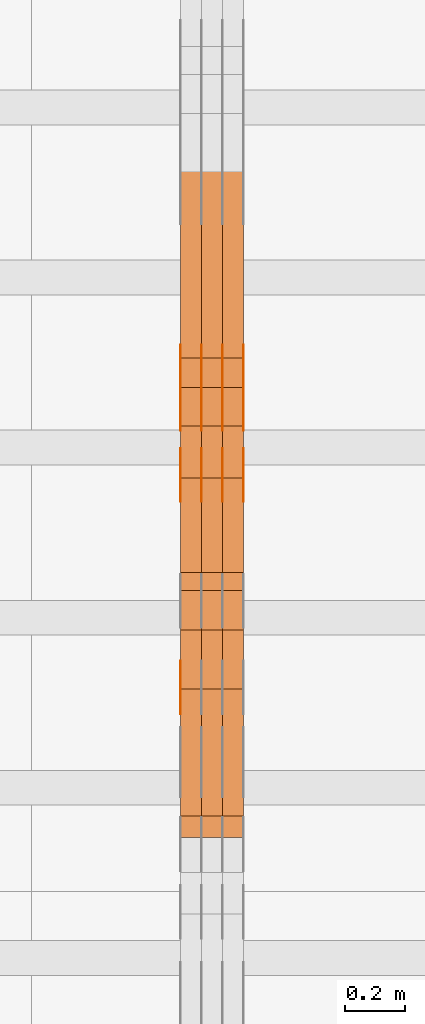
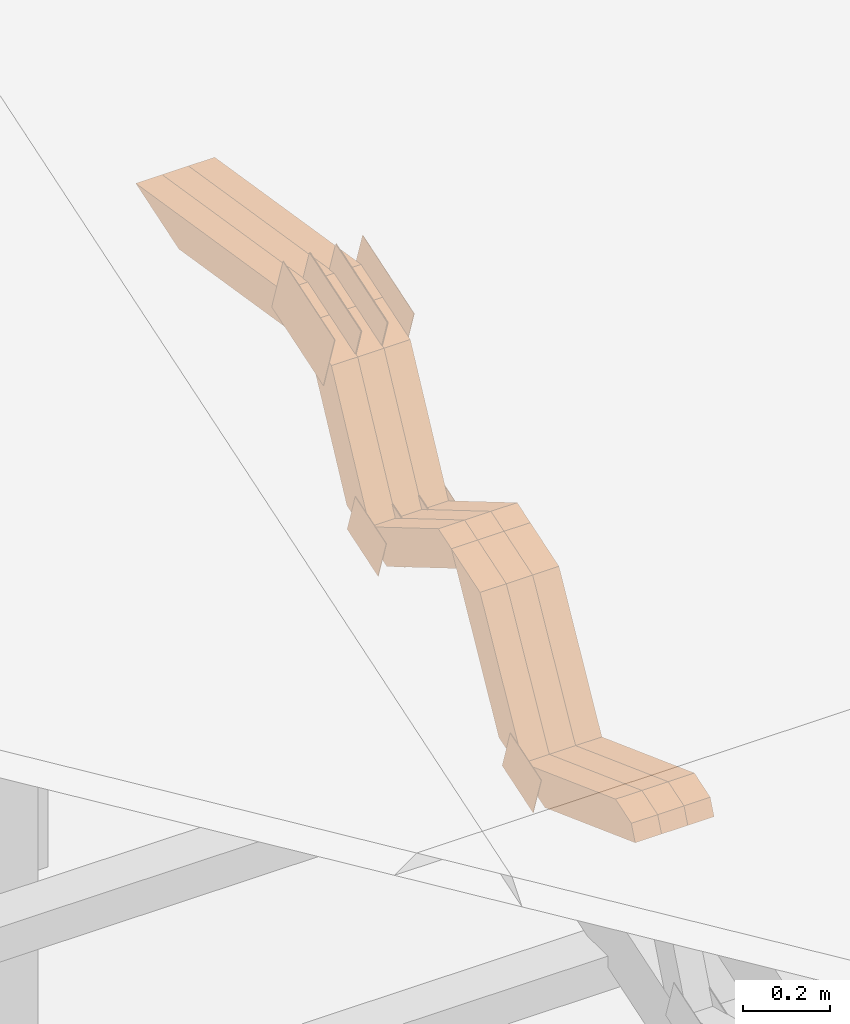
# One storey, part 276 of 385: 28 proxies.
"""IFC2X3 building model written with IfcOpenShell, lengths in millimetres."""

import ifcopenshell
import ifcopenshell.guid

model = None  # the IFC model being written
_history = None  # IfcOwnerHistory: only IFC2X3 demands one
_inside = {}  # id of a spatial element -> (the spatial element, [elements in it])
_under = {}  # id of a project, library or spatial element -> (it, [spatial elements below it])
_declared = {}  # id of a project -> (the project, [libraries it declares])
_typed = {}  # id of a type object -> (the type object, [elements of that type])
_made_of = {}  # id of a material, layer set ... -> (it, [elements and type objects made of it])


def new_model(schema):
    """Start an empty IFC model of exactly this schema.

    Asked for "IFC4X3", IfcOpenShell would pick the latest addendum, in which some entities
    have other attributes; the version numbers below select the first issue.
    IFC2X3 requires an IfcOwnerHistory on every rooted entity: one is made here for all.
    """
    global model, _history
    if schema == "IFC4X3":
        model = ifcopenshell.file(schema_version=(4, 3, 0, 0))
    else:
        model = ifcopenshell.file(schema=schema)
    _inside.clear()
    _under.clear()
    _declared.clear()
    _typed.clear()
    _made_of.clear()
    _history = None
    if model.schema == "IFC2X3":
        org = make("IfcOrganization", Name="unknown")
        user = make(
            "IfcPersonAndOrganization",
            ThePerson=make("IfcPerson", FamilyName="unknown"),
            TheOrganization=org,
        )
        app = make(
            "IfcApplication",
            ApplicationDeveloper=org,
            Version="unknown",
            ApplicationFullName="unknown",
            ApplicationIdentifier="unknown",
        )
        _history = make(
            "IfcOwnerHistory",
            OwningUser=user,
            OwningApplication=app,
            ChangeAction="ADDED",
            CreationDate=0,
        )
    return model


def make(cls, **values):
    """One entity of the class cls with the attributes given. An attribute that is None is left unset."""
    return model.create_entity(
        cls, **{name: value for name, value in values.items() if value is not None}
    )


def entity(cls, *values):
    """Any entity or typed value of the class cls, its attributes in the order of the schema. None: left unset."""
    e = model.create_entity(cls)
    for i, value in enumerate(values):
        if value is not None:
            e[i] = value
    return e


def rooted(cls, **values):
    """An entity with a GlobalId (a new one), such as an element, a storey or a relation."""
    return make(cls, GlobalId=ifcopenshell.guid.new(), OwnerHistory=_history, **values)


def si_unit(unit_type, name, prefix=None):
    """IfcSIUnit, for example si_unit("LENGTHUNIT", "METRE", prefix="MILLI")."""
    return make("IfcSIUnit", UnitType=unit_type, Prefix=prefix, Name=name)


def converted_unit(unit_type, name, factor, base, dimensions=None, offset=None):
    """IfcConversionBasedUnit, such as the inch: factor (a typed value) times the base unit."""
    return make(
        "IfcConversionBasedUnit"
        if offset is None
        else "IfcConversionBasedUnitWithOffset",
        ConversionOffset=offset,
        Dimensions=None
        if dimensions is None
        else entity("IfcDimensionalExponents", *dimensions),
        UnitType=unit_type,
        Name=name,
        ConversionFactor=make(
            "IfcMeasureWithUnit", ValueComponent=factor, UnitComponent=base
        ),
    )


def derived_unit(unit_type, elements):
    """IfcDerivedUnit: a product of units, each with its exponent."""
    return make(
        "IfcDerivedUnit",
        Elements=[
            make("IfcDerivedUnitElement", Unit=unit, Exponent=power)
            for unit, power in elements
        ],
        UnitType=unit_type,
    )


def assignment(units):
    """IfcUnitAssignment: the units of a project."""
    return None if units is None else make("IfcUnitAssignment", Units=units)


def point(xyz):
    """IfcCartesianPoint."""
    return None if xyz is None else make("IfcCartesianPoint", Coordinates=xyz)


def direction(xyz):
    """IfcDirection."""
    return None if xyz is None else make("IfcDirection", DirectionRatios=xyz)


def frame(location, z_axis=None, x_axis=None):
    """IfcAxis2Placement3D, a coordinate frame: its origin and axes. An axis left out is left unset."""
    return make(
        "IfcAxis2Placement3D",
        Location=point(location),
        Axis=direction(z_axis),
        RefDirection=direction(x_axis),
    )


def origin():
    """The frame at (0, 0, 0) with its axes left unset."""
    return frame((0.0, 0.0, 0.0))


def place(relative_to, where):
    """IfcLocalPlacement: puts the frame where relative to a parent placement (None: the world)."""
    return make(
        "IfcLocalPlacement", PlacementRelTo=relative_to, RelativePlacement=where
    )


def context(
    kind, dimensions, precision=None, world=None, true_north=None, identifier=None
):
    """IfcGeometricRepresentationContext, for example the 3D "Model" context."""
    return make(
        "IfcGeometricRepresentationContext",
        ContextIdentifier=identifier,
        ContextType=kind,
        CoordinateSpaceDimension=dimensions,
        Precision=precision,
        WorldCoordinateSystem=world,
        TrueNorth=true_north,
    )


def subcontext(parent, identifier, kind, view, scale=None):
    """IfcGeometricRepresentationSubContext, for example "Body" below "Model"."""
    return make(
        "IfcGeometricRepresentationSubContext",
        ContextIdentifier=identifier,
        ContextType=kind,
        ParentContext=parent,
        TargetScale=scale,
        TargetView=view,
    )


def project(units=None, contexts=None):
    """IfcProject with its units and contexts."""
    return rooted(
        "IfcProject",
        Name="project",
        RepresentationContexts=contexts,
        UnitsInContext=assignment(units),
    )


def spatial(cls, under=None, at=None, **own):
    """A site, building, storey or space (cls), placed at a placement, below another one or the project."""
    s = rooted(cls, ObjectPlacement=at, **own)
    if under is not None:
        _under.setdefault(under.id(), (under, []))[1].append(s)
    return s


def polyline(points):
    """IfcPolyline through the points."""
    return make("IfcPolyline", Points=[point(p) for p in points])


def outline(outer, holes=None, kind="AREA"):
    """IfcArbitraryClosedProfileDef: a profile drawn as a closed curve; with holes, ...WithVoids."""
    if holes is None:
        return make("IfcArbitraryClosedProfileDef", ProfileType=kind, OuterCurve=outer)
    return make(
        "IfcArbitraryProfileDefWithVoids",
        ProfileType=kind,
        OuterCurve=outer,
        InnerCurves=holes,
    )


def extrude(swept, where, along, depth):
    """IfcExtrudedAreaSolid: the profile swept, set in the frame where, extruded along a direction by depth."""
    return make(
        "IfcExtrudedAreaSolid",
        SweptArea=swept,
        Position=where,
        ExtrudedDirection=direction(along),
        Depth=depth,
    )


def shape(context_of_items, identifier, shape_type, items):
    """IfcShapeRepresentation: the items that make up one representation, for example the "Body"."""
    return make(
        "IfcShapeRepresentation",
        ContextOfItems=context_of_items,
        RepresentationIdentifier=identifier,
        RepresentationType=shape_type,
        Items=items,
    )


def source(mapping_origin, context_of_items, identifier, shape_type, items):
    """IfcRepresentationMap: a shape defined once, which mapped items show again and again."""
    return make(
        "IfcRepresentationMap",
        MappingOrigin=mapping_origin,
        MappedRepresentation=shape(context_of_items, identifier, shape_type, items),
    )


def transform(
    local_origin,
    x_axis=None,
    y_axis=None,
    z_axis=None,
    scale=None,
    scale2=None,
    scale3=None,
    uniform=True,
):
    """IfcCartesianTransformationOperator3D, or its non-uniform kind. x_axis, y_axis, z_axis: its Axis1, 2, 3."""
    if uniform:
        return make(
            "IfcCartesianTransformationOperator3D",
            Axis1=direction(x_axis),
            Axis2=direction(y_axis),
            LocalOrigin=point(local_origin),
            Scale=scale,
            Axis3=direction(z_axis),
        )
    return make(
        "IfcCartesianTransformationOperator3DnonUniform",
        Axis1=direction(x_axis),
        Axis2=direction(y_axis),
        LocalOrigin=point(local_origin),
        Scale=scale,
        Axis3=direction(z_axis),
        Scale2=scale2,
        Scale3=scale3,
    )


def mapped(mapping_source, mapping_target):
    """IfcMappedItem: shows the shape of a source again, moved by a transform."""
    return make(
        "IfcMappedItem", MappingSource=mapping_source, MappingTarget=mapping_target
    )


def material(Name=None, Category=None):
    """IfcMaterial."""
    return make("IfcMaterial", Name=Name, Category=Category)


def made_of(thing, what):
    """Note that an element or type object is made of a material, layer set ...; save() writes the relation."""
    if what is not None:
        _made_of.setdefault(what.id(), (what, []))[1].append(thing)
    return thing


def type_object(cls, material=None, **own):
    """A type object (cls), such as IfcWallType, which elements share."""
    return made_of(rooted(cls, **own), material)


def type_shapes(of_type, sources):
    """Give a type object the sources (RepresentationMaps) that its elements show as mapped items."""
    of_type.RepresentationMaps = sources


def element(
    cls,
    number,
    at=None,
    inside=None,
    cuts=None,
    type_object=None,
    material=None,
    context=None,
    identifier="Body",
    shape_type=None,
    held_by="IfcProductDefinitionShape",
    body=None,
    shapes=None,
    **own,
):
    """One element of the class cls, such as IfcWall. Its Tag is "e" and its number.

    at: its placement. inside: the storey or other place that contains it. cuts: it is an
    opening in that element (IfcRelVoidsElement). A single representation is given by context,
    identifier, shape_type and body (its items); several are given by shapes. held_by: the class
    of the entity that holds the representations. save() writes the other relations.
    """
    e = rooted(cls, Tag="e%d" % number, ObjectPlacement=at, **own)
    if body is not None:
        shapes = [shape(context, identifier, shape_type, body)]
    if shapes is not None:
        e.Representation = make(held_by, Representations=shapes)
    if inside is not None:
        _inside.setdefault(inside.id(), (inside, []))[1].append(e)
    if cuts is not None:
        rooted(
            "IfcRelVoidsElement", RelatingBuildingElement=cuts, RelatedOpeningElement=e
        )
    if type_object is not None:
        _typed.setdefault(type_object.id(), (type_object, []))[1].append(e)
    return made_of(e, material)


def aggregate(whole, parts):
    """IfcRelAggregates: a whole, such as a stair, and the parts it consists of."""
    return rooted("IfcRelAggregates", RelatingObject=whole, RelatedObjects=parts)


def save(model, path):
    """Write the relations noted so far, then the file.

    IfcRelAggregates (storeys below a building ...), IfcRelContainedInSpatialStructure (elements
    in a storey), IfcRelDefinesByType, IfcRelAssociatesMaterial and IfcRelDeclares: one each for
    every whole, place, type object, material and project.
    """
    for whole, parts in _under.values():
        aggregate(whole, parts)
    for where, things in _inside.values():
        rooted(
            "IfcRelContainedInSpatialStructure",
            RelatedElements=things,
            RelatingStructure=where,
        )
    for kind, things in _typed.values():
        rooted("IfcRelDefinesByType", RelatedObjects=things, RelatingType=kind)
    for what, things in _made_of.values():
        rooted("IfcRelAssociatesMaterial", RelatedObjects=things, RelatingMaterial=what)
    for by, libraries in _declared.values():
        rooted("IfcRelDeclares", RelatingContext=by, RelatedDefinitions=libraries)
    model.write(path)


model = new_model("IFC2X3")

# Units and contexts
model_context = context("Model", 3, precision=0.01, world=origin(), true_north=direction((6.12303176911189e-17, 1.0)))
body_context = subcontext(model_context, "Body", "Model", "MODEL_VIEW")
ifc_project = project(units=[si_unit("LENGTHUNIT", "METRE", prefix="MILLI"), si_unit("AREAUNIT", "SQUARE_METRE"), si_unit("VOLUMEUNIT", "CUBIC_METRE"), converted_unit("PLANEANGLEUNIT", "DEGREE", entity("IfcRatioMeasure", 0.0174532925199433), si_unit("PLANEANGLEUNIT", "RADIAN"), dimensions=[0, 0, 0, 0, 0, 0, 0]), si_unit("MASSUNIT", "GRAM", prefix="KILO"), derived_unit("MASSDENSITYUNIT", [(si_unit("MASSUNIT", "GRAM", prefix="KILO"), 1), (si_unit("LENGTHUNIT", "METRE"), -3)]), si_unit("TIMEUNIT", "SECOND"), si_unit("FREQUENCYUNIT", "HERTZ"), si_unit("THERMODYNAMICTEMPERATUREUNIT", "DEGREE_CELSIUS"), derived_unit("THERMALTRANSMITTANCEUNIT", [(si_unit("MASSUNIT", "GRAM", prefix="KILO"), 1), (si_unit("THERMODYNAMICTEMPERATUREUNIT", "KELVIN"), -1), (si_unit("TIMEUNIT", "SECOND"), -3)]), derived_unit("VOLUMETRICFLOWRATEUNIT", [(si_unit("LENGTHUNIT", "METRE"), 3), (si_unit("TIMEUNIT", "SECOND"), -1)]), si_unit("ELECTRICCURRENTUNIT", "AMPERE"), si_unit("ELECTRICVOLTAGEUNIT", "VOLT"), si_unit("POWERUNIT", "WATT"), si_unit("FORCEUNIT", "NEWTON", prefix="KILO"), si_unit("ILLUMINANCEUNIT", "LUX"), si_unit("LUMINOUSFLUXUNIT", "LUMEN"), si_unit("LUMINOUSINTENSITYUNIT", "CANDELA"), derived_unit("USERDEFINED", [(si_unit("MASSUNIT", "GRAM", prefix="KILO"), -1), (si_unit("LENGTHUNIT", "METRE"), -2), (si_unit("TIMEUNIT", "SECOND"), 3), (si_unit("LUMINOUSFLUXUNIT", "LUMEN"), 1)]), derived_unit("LINEARVELOCITYUNIT", [(si_unit("LENGTHUNIT", "METRE"), 1), (si_unit("TIMEUNIT", "SECOND"), -1)]), si_unit("PRESSUREUNIT", "PASCAL"), derived_unit("USERDEFINED", [(si_unit("LENGTHUNIT", "METRE"), -2), (si_unit("MASSUNIT", "GRAM", prefix="KILO"), 1), (si_unit("TIMEUNIT", "SECOND"), -2)])], contexts=[model_context])

# Site, building, storey
site_placement = place(None, origin())
site = spatial("IfcSite", under=ifc_project, at=site_placement, CompositionType="ELEMENT")
building_placement = place(site_placement, origin())
building = spatial("IfcBuilding", under=site, at=building_placement, CompositionType="ELEMENT")
storey_placement = place(building_placement, origin())
storey = spatial("IfcBuildingStorey", under=building, at=storey_placement, Name="Default", CompositionType="ELEMENT", Elevation=0.0)

# Proxies
ifc_material_1 = material(Name="IfcSurfaceStyle #554201")
building_element_proxy_type_1 = type_object("IfcBuildingElementProxyType", PredefinedType="NOTDEFINED", material=ifc_material_1)
shared_shape_1 = source(origin(), body_context, "Body", "SweptSolid", [
    extrude(outline(polyline([(-75.0008041947458, -59.9996998629349), (75.0007893252423, -59.9996998629349), (75.0008041947458, 59.9996998629349), (-75.0007893252423, 59.9996998629349), (-75.0008041947458, -59.9996998629349)])), frame((75.0008041947458, 60.0002282421692, 0.0), z_axis=(0.0, 0.0, 1.0), x_axis=(-1.0, 0.0, 0.0)), (0.0, 0.0, 1.0), 1.29999999999999),
])
type_shapes(building_element_proxy_type_1, [shared_shape_1])
proxy_1_placement = place(building_placement, frame((45175.0, 9291.04882812501, 2194.94482421875), z_axis=(-1.0, 0.0, 0.0), x_axis=(0.0, 0.951056516295124, 0.309016994375039)))
element("IfcBuildingElementProxy", 1, at=proxy_1_placement, inside=storey, type_object=building_element_proxy_type_1, material=ifc_material_1, context=body_context, shape_type="MappedRepresentation", body=[
    mapped(shared_shape_1, transform((0.0, 0.0, 0.0), scale=1.0)),
])
ifc_material_2 = material(Name="IfcSurfaceStyle #554144")
building_element_proxy_type_2 = type_object("IfcBuildingElementProxyType", PredefinedType="NOTDEFINED", material=ifc_material_2)
shared_shape_2 = source(origin(), body_context, "Body", "SweptSolid", [
    extrude(outline(polyline([(-124.999432723313, -83.9999457831645), (125.000177551971, -83.9999457831645), (124.999395001513, 83.9999457831646), (-125.000139830171, 83.9999457831645), (-124.999432723313, -83.9999457831645)])), frame((125.000177551971, 84.0001194377192, 0.0), z_axis=(0.0, 0.0, 1.0), x_axis=(-1.0, 0.0, 0.0)), (0.0, 0.0, 1.0), 1.3),
])
type_shapes(building_element_proxy_type_2, [shared_shape_2])
proxy_2_placement = place(building_placement, frame((45386.3, 10242.0968435407, 2855.88278137571), z_axis=(-1.0, 0.0, 0.0), x_axis=(0.0, 0.951056516295154, 0.309016994374948)))
element("IfcBuildingElementProxy", 2, at=proxy_2_placement, inside=storey, type_object=building_element_proxy_type_2, material=ifc_material_2, context=body_context, shape_type="MappedRepresentation", body=[
    mapped(shared_shape_2, transform((0.0, 0.0, 0.0), scale=1.0)),
])
ifc_material_3 = material(Name="IfcSurfaceStyle #554087")
building_element_proxy_type_3 = type_object("IfcBuildingElementProxyType", PredefinedType="NOTDEFINED", material=ifc_material_3)
shared_shape_3 = source(origin(), body_context, "Body", "SweptSolid", [
    extrude(outline(polyline([(-124.999432723313, -83.9999457831645), (125.000177551971, -83.9999457831645), (124.999395001513, 83.9999457831646), (-125.000139830171, 83.9999457831645), (-124.999432723313, -83.9999457831645)])), frame((125.000177551971, 84.0001194377192, 0.0), z_axis=(0.0, 0.0, 1.0), x_axis=(-1.0, 0.0, 0.0)), (0.0, 0.0, 1.0), 1.3),
])
type_shapes(building_element_proxy_type_3, [shared_shape_3])
proxy_3_placement = place(building_placement, frame((45315.0, 10242.0968435407, 2855.88278137571), z_axis=(-1.0, 0.0, 0.0), x_axis=(0.0, 0.951056516295154, 0.309016994374948)))
element("IfcBuildingElementProxy", 3, at=proxy_3_placement, inside=storey, type_object=building_element_proxy_type_3, material=ifc_material_3, context=body_context, shape_type="MappedRepresentation", body=[
    mapped(shared_shape_3, transform((0.0, 0.0, 0.0), scale=1.0)),
])
ifc_material_4 = material(Name="IfcSurfaceStyle #554030")
building_element_proxy_type_4 = type_object("IfcBuildingElementProxyType", PredefinedType="NOTDEFINED", material=ifc_material_4)
shared_shape_4 = source(origin(), body_context, "Body", "SweptSolid", [
    extrude(outline(polyline([(-124.999432723313, -83.9999457831645), (125.000177551971, -83.9999457831645), (124.999395001513, 83.9999457831646), (-125.000139830171, 83.9999457831645), (-124.999432723313, -83.9999457831645)])), frame((125.000177551971, 84.0001194377192, 0.0), z_axis=(0.0, 0.0, 1.0), x_axis=(-1.0, 0.0, 0.0)), (0.0, 0.0, 1.0), 1.3),
])
type_shapes(building_element_proxy_type_4, [shared_shape_4])
proxy_4_placement = place(building_placement, frame((45316.3, 10242.0968435407, 2855.88278137571), z_axis=(-1.0, 0.0, 0.0), x_axis=(0.0, 0.951056516295154, 0.309016994374948)))
element("IfcBuildingElementProxy", 4, at=proxy_4_placement, inside=storey, type_object=building_element_proxy_type_4, material=ifc_material_4, context=body_context, shape_type="MappedRepresentation", body=[
    mapped(shared_shape_4, transform((0.0, 0.0, 0.0), scale=1.0)),
])
ifc_material_5 = material(Name="IfcSurfaceStyle #553973")
building_element_proxy_type_5 = type_object("IfcBuildingElementProxyType", PredefinedType="NOTDEFINED", material=ifc_material_5)
shared_shape_5 = source(origin(), body_context, "Body", "SweptSolid", [
    extrude(outline(polyline([(-124.999432723313, -83.9999457831645), (125.000177551971, -83.9999457831645), (124.999395001513, 83.9999457831646), (-125.000139830171, 83.9999457831645), (-124.999432723313, -83.9999457831645)])), frame((125.000177551971, 84.0001194377192, 0.0), z_axis=(0.0, 0.0, 1.0), x_axis=(-1.0, 0.0, 0.0)), (0.0, 0.0, 1.0), 1.29999999999998),
])
type_shapes(building_element_proxy_type_5, [shared_shape_5])
proxy_5_placement = place(building_placement, frame((45245.0, 10242.0968435407, 2855.88278137571), z_axis=(-1.0, 0.0, 0.0), x_axis=(0.0, 0.951056516295154, 0.309016994374948)))
element("IfcBuildingElementProxy", 5, at=proxy_5_placement, inside=storey, type_object=building_element_proxy_type_5, material=ifc_material_5, context=body_context, shape_type="MappedRepresentation", body=[
    mapped(shared_shape_5, transform((0.0, 0.0, 0.0), scale=1.0)),
])
ifc_material_6 = material(Name="IfcSurfaceStyle #553916")
building_element_proxy_type_6 = type_object("IfcBuildingElementProxyType", PredefinedType="NOTDEFINED", material=ifc_material_6)
shared_shape_6 = source(origin(), body_context, "Body", "SweptSolid", [
    extrude(outline(polyline([(-124.999432723313, -83.9999457831645), (125.000177551971, -83.9999457831645), (124.999395001513, 83.9999457831646), (-125.000139830171, 83.9999457831645), (-124.999432723313, -83.9999457831645)])), frame((125.000177551971, 84.0001194377192, 0.0), z_axis=(0.0, 0.0, 1.0), x_axis=(-1.0, 0.0, 0.0)), (0.0, 0.0, 1.0), 1.29999999999998),
])
type_shapes(building_element_proxy_type_6, [shared_shape_6])
proxy_6_placement = place(building_placement, frame((45246.3, 10242.0968435407, 2855.88278137571), z_axis=(-1.0, 0.0, 0.0), x_axis=(0.0, 0.951056516295154, 0.309016994374948)))
element("IfcBuildingElementProxy", 6, at=proxy_6_placement, inside=storey, type_object=building_element_proxy_type_6, material=ifc_material_6, context=body_context, shape_type="MappedRepresentation", body=[
    mapped(shared_shape_6, transform((0.0, 0.0, 0.0), scale=1.0)),
])
ifc_material_7 = material(Name="IfcSurfaceStyle #553859")
building_element_proxy_type_7 = type_object("IfcBuildingElementProxyType", PredefinedType="NOTDEFINED", material=ifc_material_7)
shared_shape_7 = source(origin(), body_context, "Body", "SweptSolid", [
    extrude(outline(polyline([(-124.999432723313, -83.9999457831645), (125.000177551971, -83.9999457831645), (124.999395001513, 83.9999457831646), (-125.000139830171, 83.9999457831645), (-124.999432723313, -83.9999457831645)])), frame((125.000177551971, 84.0001194377192, 0.0), z_axis=(0.0, 0.0, 1.0), x_axis=(-1.0, 0.0, 0.0)), (0.0, 0.0, 1.0), 1.29999999999998),
])
type_shapes(building_element_proxy_type_7, [shared_shape_7])
proxy_7_placement = place(building_placement, frame((45175.0, 10242.0968435407, 2855.88278137571), z_axis=(-1.0, 0.0, 0.0), x_axis=(0.0, 0.951056516295154, 0.309016994374948)))
element("IfcBuildingElementProxy", 7, at=proxy_7_placement, inside=storey, type_object=building_element_proxy_type_7, material=ifc_material_7, context=body_context, shape_type="MappedRepresentation", body=[
    mapped(shared_shape_7, transform((0.0, 0.0, 0.0), scale=1.0)),
])
ifc_material_8 = material(Name="IfcSurfaceStyle #552434")
building_element_proxy_type_8 = type_object("IfcBuildingElementProxyType", PredefinedType="NOTDEFINED", material=ifc_material_8)
shared_shape_8 = source(origin(), body_context, "Body", "SweptSolid", [
    extrude(outline(polyline([(-74.9998754286189, -60.0000016373433), (74.9998605591118, -60.0000016373433), (74.9998754286189, 60.0000016373433), (-74.9998605591118, 60.0000016373433), (-74.9998754286189, -60.0000016373433)])), frame((74.9999131819004, 60.0000016373433, 0.0), z_axis=(0.0, 0.0, 1.0), x_axis=(-1.0, 0.0, 0.0)), (0.0, 0.0, 1.0), 1.3),
])
type_shapes(building_element_proxy_type_8, [shared_shape_8])
proxy_8_placement = place(building_placement, frame((45386.3, 10004.8612689908, 2426.87628052724), z_axis=(-1.0, 0.0, 0.0), x_axis=(0.0, 0.951056516295124, 0.309016994375039)))
element("IfcBuildingElementProxy", 8, at=proxy_8_placement, inside=storey, type_object=building_element_proxy_type_8, material=ifc_material_8, context=body_context, shape_type="MappedRepresentation", body=[
    mapped(shared_shape_8, transform((0.0, 0.0, 0.0), scale=1.0)),
])
ifc_material_9 = material(Name="IfcSurfaceStyle #552377")
building_element_proxy_type_9 = type_object("IfcBuildingElementProxyType", PredefinedType="NOTDEFINED", material=ifc_material_9)
shared_shape_9 = source(origin(), body_context, "Body", "SweptSolid", [
    extrude(outline(polyline([(-74.9998754286189, -60.0000016373433), (74.9998605591118, -60.0000016373433), (74.9998754286189, 60.0000016373433), (-74.9998605591118, 60.0000016373433), (-74.9998754286189, -60.0000016373433)])), frame((74.9999131819004, 60.0000016373433, 0.0), z_axis=(0.0, 0.0, 1.0), x_axis=(-1.0, 0.0, 0.0)), (0.0, 0.0, 1.0), 1.3),
])
type_shapes(building_element_proxy_type_9, [shared_shape_9])
proxy_9_placement = place(building_placement, frame((45315.0, 10004.8612689908, 2426.87628052724), z_axis=(-1.0, 0.0, 0.0), x_axis=(0.0, 0.951056516295124, 0.309016994375039)))
element("IfcBuildingElementProxy", 9, at=proxy_9_placement, inside=storey, type_object=building_element_proxy_type_9, material=ifc_material_9, context=body_context, shape_type="MappedRepresentation", body=[
    mapped(shared_shape_9, transform((0.0, 0.0, 0.0), scale=1.0)),
])
ifc_material_10 = material(Name="IfcSurfaceStyle #552320")
building_element_proxy_type_10 = type_object("IfcBuildingElementProxyType", PredefinedType="NOTDEFINED", material=ifc_material_10)
shared_shape_10 = source(origin(), body_context, "Body", "SweptSolid", [
    extrude(outline(polyline([(-74.9998754286189, -60.0000016373433), (74.9998605591118, -60.0000016373433), (74.9998754286189, 60.0000016373433), (-74.9998605591118, 60.0000016373433), (-74.9998754286189, -60.0000016373433)])), frame((74.9999131819004, 60.0000016373433, 0.0), z_axis=(0.0, 0.0, 1.0), x_axis=(-1.0, 0.0, 0.0)), (0.0, 0.0, 1.0), 1.3),
])
type_shapes(building_element_proxy_type_10, [shared_shape_10])
proxy_10_placement = place(building_placement, frame((45316.3, 10004.8612689908, 2426.87628052724), z_axis=(-1.0, 0.0, 0.0), x_axis=(0.0, 0.951056516295124, 0.309016994375039)))
element("IfcBuildingElementProxy", 10, at=proxy_10_placement, inside=storey, type_object=building_element_proxy_type_10, material=ifc_material_10, context=body_context, shape_type="MappedRepresentation", body=[
    mapped(shared_shape_10, transform((0.0, 0.0, 0.0), scale=1.0)),
])
ifc_material_11 = material(Name="IfcSurfaceStyle #552263")
building_element_proxy_type_11 = type_object("IfcBuildingElementProxyType", PredefinedType="NOTDEFINED", material=ifc_material_11)
shared_shape_11 = source(origin(), body_context, "Body", "SweptSolid", [
    extrude(outline(polyline([(-74.9998754286189, -60.0000016373433), (74.9998605591118, -60.0000016373433), (74.9998754286189, 60.0000016373433), (-74.9998605591118, 60.0000016373433), (-74.9998754286189, -60.0000016373433)])), frame((74.9999131819004, 60.0000016373433, 0.0), z_axis=(0.0, 0.0, 1.0), x_axis=(-1.0, 0.0, 0.0)), (0.0, 0.0, 1.0), 1.29999999999999),
])
type_shapes(building_element_proxy_type_11, [shared_shape_11])
proxy_11_placement = place(building_placement, frame((45245.0, 10004.8612689908, 2426.87628052724), z_axis=(-1.0, 0.0, 0.0), x_axis=(0.0, 0.951056516295124, 0.309016994375039)))
element("IfcBuildingElementProxy", 11, at=proxy_11_placement, inside=storey, type_object=building_element_proxy_type_11, material=ifc_material_11, context=body_context, shape_type="MappedRepresentation", body=[
    mapped(shared_shape_11, transform((0.0, 0.0, 0.0), scale=1.0)),
])
ifc_material_12 = material(Name="IfcSurfaceStyle #552206")
building_element_proxy_type_12 = type_object("IfcBuildingElementProxyType", PredefinedType="NOTDEFINED", material=ifc_material_12)
shared_shape_12 = source(origin(), body_context, "Body", "SweptSolid", [
    extrude(outline(polyline([(-74.9998754286189, -60.0000016373433), (74.9998605591118, -60.0000016373433), (74.9998754286189, 60.0000016373433), (-74.9998605591118, 60.0000016373433), (-74.9998754286189, -60.0000016373433)])), frame((74.9999131819004, 60.0000016373433, 0.0), z_axis=(0.0, 0.0, 1.0), x_axis=(-1.0, 0.0, 0.0)), (0.0, 0.0, 1.0), 1.29999999999999),
])
type_shapes(building_element_proxy_type_12, [shared_shape_12])
proxy_12_placement = place(building_placement, frame((45246.3, 10004.8612689908, 2426.87628052724), z_axis=(-1.0, 0.0, 0.0), x_axis=(0.0, 0.951056516295124, 0.309016994375039)))
element("IfcBuildingElementProxy", 12, at=proxy_12_placement, inside=storey, type_object=building_element_proxy_type_12, material=ifc_material_12, context=body_context, shape_type="MappedRepresentation", body=[
    mapped(shared_shape_12, transform((0.0, 0.0, 0.0), scale=1.0)),
])
ifc_material_13 = material(Name="IfcSurfaceStyle #552149")
building_element_proxy_type_13 = type_object("IfcBuildingElementProxyType", PredefinedType="NOTDEFINED", material=ifc_material_13)
shared_shape_13 = source(origin(), body_context, "Body", "SweptSolid", [
    extrude(outline(polyline([(-74.9998754286189, -60.0000016373433), (74.9998605591118, -60.0000016373433), (74.9998754286189, 60.0000016373433), (-74.9998605591118, 60.0000016373433), (-74.9998754286189, -60.0000016373433)])), frame((74.9999131819004, 60.0000016373433, 0.0), z_axis=(0.0, 0.0, 1.0), x_axis=(-1.0, 0.0, 0.0)), (0.0, 0.0, 1.0), 1.29999999999999),
])
type_shapes(building_element_proxy_type_13, [shared_shape_13])
proxy_13_placement = place(building_placement, frame((45175.0, 10004.8612689908, 2426.87628052724), z_axis=(-1.0, 0.0, 0.0), x_axis=(0.0, 0.951056516295124, 0.309016994375039)))
element("IfcBuildingElementProxy", 13, at=proxy_13_placement, inside=storey, type_object=building_element_proxy_type_13, material=ifc_material_13, context=body_context, shape_type="MappedRepresentation", body=[
    mapped(shared_shape_13, transform((0.0, 0.0, 0.0), scale=1.0)),
])
ifc_material_14 = material(Name="IfcSurfaceStyle #532112")
building_element_proxy_type_14 = type_object("IfcBuildingElementProxyType", Name="T1-W5 532110", PredefinedType="NOTDEFINED", material=ifc_material_14)
shared_shape_14 = source(origin(), body_context, "Body", "SweptSolid", [
    extrude(outline(polyline([(-301.214270081322, -47.5000783565111), (303.980395954293, -47.5000783565111), (288.664123931657, 0.000197935560590153), (195.704076557203, 47.4999793887309), (-487.134326361831, 47.4999793887309), (-301.214270081322, -47.5000783565111)])), frame((303.980395954293, 47.5001815410909, 0.0), z_axis=(0.0, 0.0, 1.0), x_axis=(-1.0, 0.0, 0.0)), (0.0, 0.0, 1.0), 70.0),
])
type_shapes(building_element_proxy_type_14, [shared_shape_14])
proxy_14_placement = place(building_placement, frame((45385.0, 10379.2051671398, 2863.91176079486), z_axis=(-1.0, 0.0, 0.0), x_axis=(0.0, 0.987508363398486, -0.1575665961365)))
element("IfcBuildingElementProxy", 14, at=proxy_14_placement, inside=storey, type_object=building_element_proxy_type_14, material=ifc_material_14, Name="T1-W5", context=body_context, shape_type="MappedRepresentation", body=[
    mapped(shared_shape_14, transform((0.0, 0.0, 0.0), scale=1.0)),
])
ifc_material_15 = material(Name="IfcSurfaceStyle #532046")
building_element_proxy_type_15 = type_object("IfcBuildingElementProxyType", Name="T1-W5 532044", PredefinedType="NOTDEFINED", material=ifc_material_15)
shared_shape_15 = source(origin(), body_context, "Body", "SweptSolid", [
    extrude(outline(polyline([(-301.214270081322, -47.5000783565111), (303.980395954293, -47.5000783565111), (288.664123931657, 0.000197935560590153), (195.704076557203, 47.4999793887309), (-487.134326361831, 47.4999793887309), (-301.214270081322, -47.5000783565111)])), frame((303.980395954293, 47.5001815410909, 0.0), z_axis=(0.0, 0.0, 1.0), x_axis=(-1.0, 0.0, 0.0)), (0.0, 0.0, 1.0), 70.0),
])
type_shapes(building_element_proxy_type_15, [shared_shape_15])
proxy_15_placement = place(building_placement, frame((45315.0, 10379.2051671398, 2863.91176079486), z_axis=(-1.0, 0.0, 0.0), x_axis=(0.0, 0.987508363398486, -0.1575665961365)))
element("IfcBuildingElementProxy", 15, at=proxy_15_placement, inside=storey, type_object=building_element_proxy_type_15, material=ifc_material_15, Name="T1-W5", context=body_context, shape_type="MappedRepresentation", body=[
    mapped(shared_shape_15, transform((0.0, 0.0, 0.0), scale=1.0)),
])
ifc_material_16 = material(Name="IfcSurfaceStyle #531980")
building_element_proxy_type_16 = type_object("IfcBuildingElementProxyType", Name="T1-W5 531978", PredefinedType="NOTDEFINED", material=ifc_material_16)
shared_shape_16 = source(origin(), body_context, "Body", "SweptSolid", [
    extrude(outline(polyline([(-301.214270081322, -47.5000783565111), (303.980395954293, -47.5000783565111), (288.664123931657, 0.000197935560590153), (195.704076557203, 47.4999793887309), (-487.134326361831, 47.4999793887309), (-301.214270081322, -47.5000783565111)])), frame((303.980395954293, 47.5001815410909, 0.0), z_axis=(0.0, 0.0, 1.0), x_axis=(-1.0, 0.0, 0.0)), (0.0, 0.0, 1.0), 70.0),
])
type_shapes(building_element_proxy_type_16, [shared_shape_16])
proxy_16_placement = place(building_placement, frame((45245.0, 10379.2051671398, 2863.91176079486), z_axis=(-1.0, 0.0, 0.0), x_axis=(0.0, 0.987508363398486, -0.1575665961365)))
element("IfcBuildingElementProxy", 16, at=proxy_16_placement, inside=storey, type_object=building_element_proxy_type_16, material=ifc_material_16, Name="T1-W5", context=body_context, shape_type="MappedRepresentation", body=[
    mapped(shared_shape_16, transform((0.0, 0.0, 0.0), scale=1.0)),
])
ifc_material_17 = material(Name="IfcSurfaceStyle #531716")
building_element_proxy_type_17 = type_object("IfcBuildingElementProxyType", Name="T1-W37 531714", PredefinedType="NOTDEFINED", material=ifc_material_17)
shared_shape_17 = source(origin(), body_context, "Body", "SweptSolid", [
    extrude(outline(polyline([(111.787482004227, -179.289397746839), (245.990585035629, -179.289397746839), (-64.0177573255029, 131.410401861866), (-131.116409377007, 131.410958895698), (-162.643900337347, 95.757434736113), (111.787482004227, -179.289397746839)])), frame((185.635323570343, 47.5011799885346, 0.0), z_axis=(0.0, 0.0, 1.0), x_axis=(0.706316677358935, 0.707896003156279, 0.0)), (0.0, 0.0, 1.0), 70.0),
])
type_shapes(building_element_proxy_type_17, [shared_shape_17])
proxy_17_placement = place(building_placement, frame((45385.0, 10081.8581176196, 2424.08390440728), z_axis=(-1.0, 0.0, 0.0), x_axis=(0.0, 0.452995827831714, 0.891512635898707)))
element("IfcBuildingElementProxy", 17, at=proxy_17_placement, inside=storey, type_object=building_element_proxy_type_17, material=ifc_material_17, Name="T1-W37", context=body_context, shape_type="MappedRepresentation", body=[
    mapped(shared_shape_17, transform((0.0, 0.0, 0.0), scale=1.0)),
])
ifc_material_18 = material(Name="IfcSurfaceStyle #531650")
building_element_proxy_type_18 = type_object("IfcBuildingElementProxyType", Name="T1-W37 531648", PredefinedType="NOTDEFINED", material=ifc_material_18)
shared_shape_18 = source(origin(), body_context, "Body", "SweptSolid", [
    extrude(outline(polyline([(111.787482004227, -179.289397746839), (245.990585035629, -179.289397746839), (-64.0177573255029, 131.410401861866), (-131.116409377007, 131.410958895698), (-162.643900337347, 95.757434736113), (111.787482004227, -179.289397746839)])), frame((185.635323570343, 47.5011799885346, 0.0), z_axis=(0.0, 0.0, 1.0), x_axis=(0.706316677358935, 0.707896003156279, 0.0)), (0.0, 0.0, 1.0), 70.0),
])
type_shapes(building_element_proxy_type_18, [shared_shape_18])
proxy_18_placement = place(building_placement, frame((45315.0, 10081.8581176196, 2424.08390440728), z_axis=(-1.0, 0.0, 0.0), x_axis=(0.0, 0.452995827831714, 0.891512635898707)))
element("IfcBuildingElementProxy", 18, at=proxy_18_placement, inside=storey, type_object=building_element_proxy_type_18, material=ifc_material_18, Name="T1-W37", context=body_context, shape_type="MappedRepresentation", body=[
    mapped(shared_shape_18, transform((0.0, 0.0, 0.0), scale=1.0)),
])
ifc_material_19 = material(Name="IfcSurfaceStyle #531584")
building_element_proxy_type_19 = type_object("IfcBuildingElementProxyType", Name="T1-W37 531582", PredefinedType="NOTDEFINED", material=ifc_material_19)
shared_shape_19 = source(origin(), body_context, "Body", "SweptSolid", [
    extrude(outline(polyline([(111.787482004227, -179.289397746839), (245.990585035629, -179.289397746839), (-64.0177573255029, 131.410401861866), (-131.116409377007, 131.410958895698), (-162.643900337347, 95.757434736113), (111.787482004227, -179.289397746839)])), frame((185.635323570343, 47.5011799885346, 0.0), z_axis=(0.0, 0.0, 1.0), x_axis=(0.706316677358935, 0.707896003156279, 0.0)), (0.0, 0.0, 1.0), 70.0),
])
type_shapes(building_element_proxy_type_19, [shared_shape_19])
proxy_19_placement = place(building_placement, frame((45245.0, 10081.8581176196, 2424.08390440728), z_axis=(-1.0, 0.0, 0.0), x_axis=(0.0, 0.452995827831714, 0.891512635898707)))
element("IfcBuildingElementProxy", 19, at=proxy_19_placement, inside=storey, type_object=building_element_proxy_type_19, material=ifc_material_19, Name="T1-W37", context=body_context, shape_type="MappedRepresentation", body=[
    mapped(shared_shape_19, transform((0.0, 0.0, 0.0), scale=1.0)),
])
ifc_material_20 = material(Name="IfcSurfaceStyle #531320")
building_element_proxy_type_20 = type_object("IfcBuildingElementProxyType", Name="T1-W43 531318", PredefinedType="NOTDEFINED", material=ifc_material_20)
shared_shape_20 = source(origin(), body_context, "Body", "SweptSolid", [
    extrude(outline(polyline([(-198.159905426436, -47.4999961988362), (173.155878681738, -47.4999961988362), (174.585865234707, -0.00038778214839239), (132.582704932703, 47.5001900899104), (-282.164543422712, 47.5001900899104), (-198.159905426436, -47.4999961988362)])), frame((174.585865234707, 47.5001900899104, 0.0), z_axis=(0.0, 0.0, 1.0), x_axis=(-1.0, 0.0, 0.0)), (0.0, 0.0, 1.0), 70.0),
])
type_shapes(building_element_proxy_type_20, [shared_shape_20])
proxy_20_placement = place(building_placement, frame((45385.0, 9730.71877771153, 2634.4881681647), z_axis=(-1.0, 0.0, 0.0), x_axis=(0.0, 0.861495156633645, -0.507765787639115)))
element("IfcBuildingElementProxy", 20, at=proxy_20_placement, inside=storey, type_object=building_element_proxy_type_20, material=ifc_material_20, Name="T1-W43", context=body_context, shape_type="MappedRepresentation", body=[
    mapped(shared_shape_20, transform((0.0, 0.0, 0.0), scale=1.0)),
])
ifc_material_21 = material(Name="IfcSurfaceStyle #531254")
building_element_proxy_type_21 = type_object("IfcBuildingElementProxyType", Name="T1-W43 531252", PredefinedType="NOTDEFINED", material=ifc_material_21)
shared_shape_21 = source(origin(), body_context, "Body", "SweptSolid", [
    extrude(outline(polyline([(-198.159905426436, -47.4999961988362), (173.155878681738, -47.4999961988362), (174.585865234707, -0.00038778214839239), (132.582704932703, 47.5001900899104), (-282.164543422712, 47.5001900899104), (-198.159905426436, -47.4999961988362)])), frame((174.585865234707, 47.5001900899104, 0.0), z_axis=(0.0, 0.0, 1.0), x_axis=(-1.0, 0.0, 0.0)), (0.0, 0.0, 1.0), 70.0),
])
type_shapes(building_element_proxy_type_21, [shared_shape_21])
proxy_21_placement = place(building_placement, frame((45315.0, 9730.71877771153, 2634.4881681647), z_axis=(-1.0, 0.0, 0.0), x_axis=(0.0, 0.861495156633645, -0.507765787639115)))
element("IfcBuildingElementProxy", 21, at=proxy_21_placement, inside=storey, type_object=building_element_proxy_type_21, material=ifc_material_21, Name="T1-W43", context=body_context, shape_type="MappedRepresentation", body=[
    mapped(shared_shape_21, transform((0.0, 0.0, 0.0), scale=1.0)),
])
ifc_material_22 = material(Name="IfcSurfaceStyle #531188")
building_element_proxy_type_22 = type_object("IfcBuildingElementProxyType", Name="T1-W43 531186", PredefinedType="NOTDEFINED", material=ifc_material_22)
shared_shape_22 = source(origin(), body_context, "Body", "SweptSolid", [
    extrude(outline(polyline([(-198.159905426436, -47.4999961988362), (173.155878681738, -47.4999961988362), (174.585865234707, -0.00038778214839239), (132.582704932703, 47.5001900899104), (-282.164543422712, 47.5001900899104), (-198.159905426436, -47.4999961988362)])), frame((174.585865234707, 47.5001900899104, 0.0), z_axis=(0.0, 0.0, 1.0), x_axis=(-1.0, 0.0, 0.0)), (0.0, 0.0, 1.0), 70.0),
])
type_shapes(building_element_proxy_type_22, [shared_shape_22])
proxy_22_placement = place(building_placement, frame((45245.0, 9730.71877771153, 2634.4881681647), z_axis=(-1.0, 0.0, 0.0), x_axis=(0.0, 0.861495156633645, -0.507765787639115)))
element("IfcBuildingElementProxy", 22, at=proxy_22_placement, inside=storey, type_object=building_element_proxy_type_22, material=ifc_material_22, Name="T1-W43", context=body_context, shape_type="MappedRepresentation", body=[
    mapped(shared_shape_22, transform((0.0, 0.0, 0.0), scale=1.0)),
])
ifc_material_23 = material(Name="IfcSurfaceStyle #530924")
building_element_proxy_type_23 = type_object("IfcBuildingElementProxyType", Name="T1-W33 530922", PredefinedType="NOTDEFINED", material=ifc_material_23)
shared_shape_23 = source(origin(), body_context, "Body", "SweptSolid", [
    extrude(outline(polyline([(-314.173070820175, -47.4997758466969), (139.635944117881, -47.4997758466969), (190.204920608233, 0.000348187720347082), (197.369205310989, 47.5001702328475), (-213.036999216928, 47.4990332728259), (-314.173070820175, -47.4997758466969)])), frame((197.369205310989, 47.5001702328475, 0.0), z_axis=(0.0, 0.0, 1.0), x_axis=(-1.0, 0.0, 0.0)), (0.0, 0.0, 1.0), 70.0),
])
type_shapes(building_element_proxy_type_23, [shared_shape_23])
proxy_23_placement = place(building_placement, frame((45385.0, 9376.96875, 2191.01977539063), z_axis=(-1.0, 0.0, 0.0), x_axis=(0.0, 0.481632628948835, 0.876373214293907)))
element("IfcBuildingElementProxy", 23, at=proxy_23_placement, inside=storey, type_object=building_element_proxy_type_23, material=ifc_material_23, Name="T1-W33", context=body_context, shape_type="MappedRepresentation", body=[
    mapped(shared_shape_23, transform((0.0, 0.0, 0.0), scale=1.0)),
])
ifc_material_24 = material(Name="IfcSurfaceStyle #530858")
building_element_proxy_type_24 = type_object("IfcBuildingElementProxyType", Name="T1-W33 530856", PredefinedType="NOTDEFINED", material=ifc_material_24)
shared_shape_24 = source(origin(), body_context, "Body", "SweptSolid", [
    extrude(outline(polyline([(-314.173070820175, -47.4997758466969), (139.635944117881, -47.4997758466969), (190.204920608233, 0.000348187720347082), (197.369205310989, 47.5001702328475), (-213.036999216928, 47.4990332728259), (-314.173070820175, -47.4997758466969)])), frame((197.369205310989, 47.5001702328475, 0.0), z_axis=(0.0, 0.0, 1.0), x_axis=(-1.0, 0.0, 0.0)), (0.0, 0.0, 1.0), 70.0),
])
type_shapes(building_element_proxy_type_24, [shared_shape_24])
proxy_24_placement = place(building_placement, frame((45315.0, 9376.96875, 2191.01977539063), z_axis=(-1.0, 0.0, 0.0), x_axis=(0.0, 0.481632628948835, 0.876373214293907)))
element("IfcBuildingElementProxy", 24, at=proxy_24_placement, inside=storey, type_object=building_element_proxy_type_24, material=ifc_material_24, Name="T1-W33", context=body_context, shape_type="MappedRepresentation", body=[
    mapped(shared_shape_24, transform((0.0, 0.0, 0.0), scale=1.0)),
])
ifc_material_25 = material(Name="IfcSurfaceStyle #530792")
building_element_proxy_type_25 = type_object("IfcBuildingElementProxyType", Name="T1-W33 530790", PredefinedType="NOTDEFINED", material=ifc_material_25)
shared_shape_25 = source(origin(), body_context, "Body", "SweptSolid", [
    extrude(outline(polyline([(-314.173070820175, -47.4997758466969), (139.635944117881, -47.4997758466969), (190.204920608233, 0.000348187720347082), (197.369205310989, 47.5001702328475), (-213.036999216928, 47.4990332728259), (-314.173070820175, -47.4997758466969)])), frame((197.369205310989, 47.5001702328475, 0.0), z_axis=(0.0, 0.0, 1.0), x_axis=(-1.0, 0.0, 0.0)), (0.0, 0.0, 1.0), 70.0),
])
type_shapes(building_element_proxy_type_25, [shared_shape_25])
proxy_25_placement = place(building_placement, frame((45245.0, 9376.96875, 2191.01977539063), z_axis=(-1.0, 0.0, 0.0), x_axis=(0.0, 0.481632628948835, 0.876373214293907)))
element("IfcBuildingElementProxy", 25, at=proxy_25_placement, inside=storey, type_object=building_element_proxy_type_25, material=ifc_material_25, Name="T1-W33", context=body_context, shape_type="MappedRepresentation", body=[
    mapped(shared_shape_25, transform((0.0, 0.0, 0.0), scale=1.0)),
])
ifc_material_26 = material(Name="IfcSurfaceStyle #530528")
building_element_proxy_type_26 = type_object("IfcBuildingElementProxyType", Name="T1-W25 530526", PredefinedType="NOTDEFINED", material=ifc_material_26)
shared_shape_26 = source(origin(), body_context, "Body", "SweptSolid", [
    extrude(outline(polyline([(-229.232772462784, -47.5001671709529), (214.075939394384, -47.5001671709529), (212.688957821661, -0.000141058964427199), (152.358910178478, 47.5002377004352), (-349.891034931738, 47.5002377004352), (-229.232772462784, -47.5001671709529)])), frame((214.075939394384, 47.5002377004352, 0.0), z_axis=(0.0, 0.0, 1.0), x_axis=(-1.0, 0.0, 0.0)), (0.0, 0.0, 1.0), 70.0),
])
type_shapes(building_element_proxy_type_26, [shared_shape_26])
proxy_26_placement = place(building_placement, frame((45385.0, 8892.81895960243, 2369.29665807578), z_axis=(-1.0, 0.0, 0.0), x_axis=(0.0, 0.938402514401222, -0.345544094097213)))
element("IfcBuildingElementProxy", 26, at=proxy_26_placement, inside=storey, type_object=building_element_proxy_type_26, material=ifc_material_26, Name="T1-W25", context=body_context, shape_type="MappedRepresentation", body=[
    mapped(shared_shape_26, transform((0.0, 0.0, 0.0), scale=1.0)),
])
ifc_material_27 = material(Name="IfcSurfaceStyle #530462")
building_element_proxy_type_27 = type_object("IfcBuildingElementProxyType", Name="T1-W25 530460", PredefinedType="NOTDEFINED", material=ifc_material_27)
shared_shape_27 = source(origin(), body_context, "Body", "SweptSolid", [
    extrude(outline(polyline([(-229.232772462784, -47.5001671709529), (214.075939394384, -47.5001671709529), (212.688957821661, -0.000141058964427199), (152.358910178478, 47.5002377004352), (-349.891034931738, 47.5002377004352), (-229.232772462784, -47.5001671709529)])), frame((214.075939394384, 47.5002377004352, 0.0), z_axis=(0.0, 0.0, 1.0), x_axis=(-1.0, 0.0, 0.0)), (0.0, 0.0, 1.0), 70.0),
])
type_shapes(building_element_proxy_type_27, [shared_shape_27])
proxy_27_placement = place(building_placement, frame((45315.0, 8892.81895960243, 2369.29665807578), z_axis=(-1.0, 0.0, 0.0), x_axis=(0.0, 0.938402514401222, -0.345544094097213)))
element("IfcBuildingElementProxy", 27, at=proxy_27_placement, inside=storey, type_object=building_element_proxy_type_27, material=ifc_material_27, Name="T1-W25", context=body_context, shape_type="MappedRepresentation", body=[
    mapped(shared_shape_27, transform((0.0, 0.0, 0.0), scale=1.0)),
])
ifc_material_28 = material(Name="IfcSurfaceStyle #530396")
building_element_proxy_type_28 = type_object("IfcBuildingElementProxyType", Name="T1-W25 530394", PredefinedType="NOTDEFINED", material=ifc_material_28)
shared_shape_28 = source(origin(), body_context, "Body", "SweptSolid", [
    extrude(outline(polyline([(-229.232772462784, -47.5001671709529), (214.075939394384, -47.5001671709529), (212.688957821661, -0.000141058964427199), (152.358910178478, 47.5002377004352), (-349.891034931738, 47.5002377004352), (-229.232772462784, -47.5001671709529)])), frame((214.075939394384, 47.5002377004352, 0.0), z_axis=(0.0, 0.0, 1.0), x_axis=(-1.0, 0.0, 0.0)), (0.0, 0.0, 1.0), 70.0),
])
type_shapes(building_element_proxy_type_28, [shared_shape_28])
proxy_28_placement = place(building_placement, frame((45245.0, 8892.81895960243, 2369.29665807578), z_axis=(-1.0, 0.0, 0.0), x_axis=(0.0, 0.938402514401222, -0.345544094097213)))
element("IfcBuildingElementProxy", 28, at=proxy_28_placement, inside=storey, type_object=building_element_proxy_type_28, material=ifc_material_28, Name="T1-W25", context=body_context, shape_type="MappedRepresentation", body=[
    mapped(shared_shape_28, transform((0.0, 0.0, 0.0), scale=1.0)),
])

save(model, "model.ifc")
